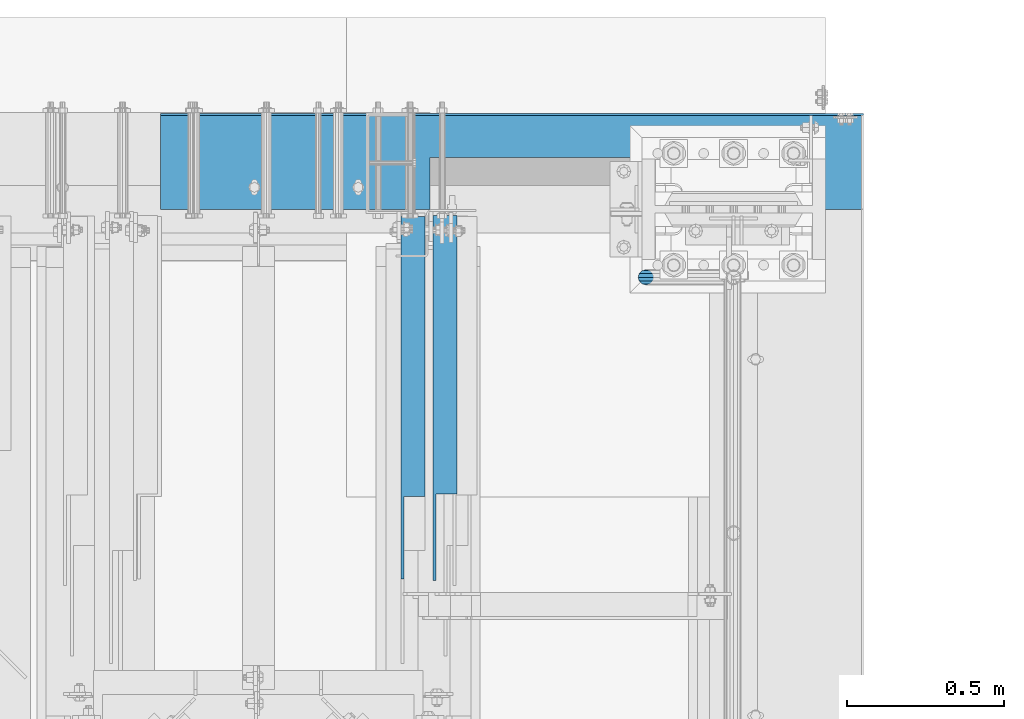
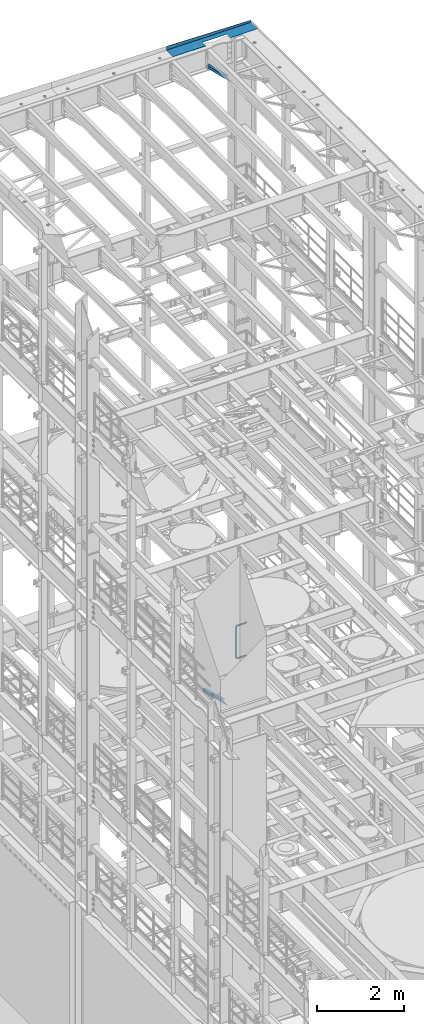
# One storey, part 1074 of 1876: 4 beams, 4 elements without a shape of their own.
"""IFC2X3 building model written with IfcOpenShell, lengths in millimetres."""

from ifc_helpers import new_model, si_unit, frame, origin_with_axes, place, context, subcontext, project, spatial, faceted_brep, material, type_object, element, aggregate, save


model = new_model("IFC2X3")

# Units and contexts
model_context = context("Model", 3, precision=1e-05, world=origin_with_axes())
body_context = subcontext(model_context, "Body", "Model", "MODEL_VIEW")
ifc_project = project(units=[si_unit("LENGTHUNIT", "METRE", prefix="MILLI"), si_unit("AREAUNIT", "SQUARE_METRE"), si_unit("VOLUMEUNIT", "CUBIC_METRE"), si_unit("MASSUNIT", "GRAM", prefix="KILO"), si_unit("TIMEUNIT", "SECOND"), si_unit("PLANEANGLEUNIT", "RADIAN"), si_unit("SOLIDANGLEUNIT", "STERADIAN"), si_unit("THERMODYNAMICTEMPERATUREUNIT", "DEGREE_CELSIUS"), si_unit("LUMINOUSINTENSITYUNIT", "LUMEN")], contexts=[model_context])

# Site, building, storey
site_placement = place(None, origin_with_axes())
site = spatial("IfcSite", under=ifc_project, at=site_placement, CompositionType="ELEMENT")
building_placement = place(site_placement, origin_with_axes())
building = spatial("IfcBuilding", under=site, at=building_placement, Name="Undefined", CompositionType="ELEMENT")
storey_placement = place(building_placement, origin_with_axes())
storey = spatial("IfcBuildingStorey", under=building, at=storey_placement, Name="Undefined", CompositionType="ELEMENT", Elevation=0.0)

# Assembly, beam
assembly_1_placement = place(storey_placement, origin_with_axes())
assembly_1 = element("IfcElementAssembly", 1, at=assembly_1_placement, inside=storey, Name="RAIL", AssemblyPlace="NOTDEFINED", PredefinedType="RIGID_FRAME")
ifc_material_1 = material()
beam_type_1 = type_object("IfcBeamType", Name="PIPE1-1/2SCH40", PredefinedType="NOTDEFINED")
beam_1_placement = place(assembly_1_placement, frame((7619.99999999999, 13499.7063, 6207.125), z_axis=(0.0, 0.0, 1.0), x_axis=(-1.0, 0.0, 0.0)))
beam_1 = element("IfcBeam", 2, at=beam_1_placement, type_object=beam_type_1, material=ifc_material_1, Name="RAIL", ObjectType="PIPE1-1/2SCH40", context=body_context, shape_type="Brep", body=[
    faceted_brep([(1.20714750983051e-12, 24.1299999999974, -914.399963378906), (12.0650000000014, 20.8971929933159, -926.464963378905), (12.0650000000014, 20.8971929933177, -902.334963378908), (12.0650000000014, -20.8971929933195, -902.334963378908), (12.0650000000014, -20.8971929933195, -926.464963378905), (1.52133659548828e-12, -24.130000000001, -914.399963378906), (20.8971929933199, -12.0650000000023, -893.502770385589), (20.8971929933199, -12.0650000000005, -898.533841947723), (15.2545715621378, -17.7076214311819, -904.176463378906), (12.5151929933181, -20.4470000000019, -914.399963378906), (15.2545715621376, -17.7076214311819, -924.623463378906), (20.8971929933199, -12.0650000000005, -930.26608481009), (20.8971929933199, -12.0650000000023, -935.297156372224), (24.1300000000014, -1.81898940354586e-12, -934.846963378906), (24.1300000000014, -1.81898940354586e-12, -938.529963378907), (21.3906214311813, -10.2235000000019, -932.107584810088), (21.3906214311823, 10.2234999999982, -932.107584810088), (20.8971929933199, 12.0650000000005, -930.266084810086), (20.8971929933199, 12.0649999999987, -935.297156372224), (15.2545715621413, 17.7076214311783, -924.623463378906), (12.5151929933216, 20.4469999999983, -914.399963378906), (15.2545715621411, 17.7076214311783, -904.176463378906), (20.8971929933199, 12.0650000000005, -898.533841947727), (20.8971929933199, 12.0649999999987, -893.502770385589), (21.3906214311822, 10.2234999999982, -896.692341947724), (24.1300000000014, 0.0, -893.952963378906), (24.1300000000014, 0.0, -890.269963378905), (21.3906214311814, -10.2235000000019, -896.692341947724), (241.299995422363, 20.8971929933177, -12.0649999999987), (241.299995422363, 24.1299999999992, 0.0), (253.073542436527, 24.1299999999992, -1.86474665447167), (249.345252399393, 20.8971929933177, -13.3392435235728), (241.299995422363, 12.0650000000005, -20.8971929933177), (246.615954666858, 12.0650000000005, -21.7391582230448), (241.299995422363, 0.0, -24.130000000001), (245.616962362259, 0.0, -24.8137403926739), (241.299995422363, -12.0650000000005, -20.8971929933177), (246.615954666858, -12.0650000000005, -21.7391582230448), (241.299995422363, -20.8971929933177, -12.0649999999987), (249.345252399393, -20.8971929933177, -13.3392435235728), (241.299995422363, -24.1299999999992, 0.0), (253.073542436527, -24.1299999999992, -1.86474665447167), (241.299995422363, -20.8971929933177, 12.0649999999987), (256.801832473661, -20.8971929933177, 9.60975021462946), (241.299995422363, -12.0650000000005, 20.8971929933177), (259.531130206197, -12.0650000000005, 18.0096649141014), (241.299995422363, 0.0, 24.130000000001), (260.530122510796, 0.0, 21.084247083727), (241.299995422363, 12.0650000000005, 20.8971929933177), (259.531130206197, 12.0650000000005, 18.0096649141014), (241.299995422363, 20.8971929933177, 12.0649999999987), (256.801832473661, 20.8971929933177, 9.60975021462946), (291.464993896486, -20.8971929933177, -38.0999984741211), (279.399993896484, -24.1299999999992, -38.0999984741211), (279.399993896484, -24.1299999999992, -876.299964904785), (291.464993896484, -20.8971929933177, -876.299964904785), (267.334993896485, -20.8971929933177, -38.0999984741211), (267.334993896484, -20.8971929933177, -876.299964904785), (258.502800903167, -12.0650000000005, -38.0999984741211), (258.502800903166, -12.0650000000005, -876.299964904785), (255.269993896485, 0.0, -38.0999984741211), (255.269993896484, 0.0, -876.299964904785), (258.502800903167, 12.0650000000005, -38.0999984741211), (258.502800903166, 12.0650000000005, -876.299964904785), (267.334993896485, 20.8971929933177, -38.0999984741211), (267.334993896484, 20.8971929933177, -876.299964904785), (279.399993896485, 24.1299999999992, -38.0999984741211), (279.399993896484, 24.1299999999992, -876.299964904785), (291.464993896486, 20.8971929933177, -38.0999984741211), (291.464993896484, 20.8971929933177, -876.299964904785), (300.297186889804, 12.0650000000005, -38.0999984741211), (300.297186889803, 12.0650000000005, -876.299964904785), (303.529993896486, 0.0, -38.0999984741211), (303.529993896484, 0.0, -876.299964904785), (300.297186889804, -12.0650000000005, -38.0999984741211), (300.297186889803, -12.0650000000005, -876.299964904785), (297.409658810584, -12.0650000000005, -894.531099688622), (300.484240980214, 0.0, -895.53009199322), (297.409658810584, 12.0650000000005, -894.531099688622), (289.009744111112, 20.8971929933177, -891.801801956084), (277.535247242011, 24.1299999999992, -888.073511918952), (266.06075037291, 20.8971929933177, -884.345221881817), (257.660835673438, 12.0650000000005, -881.615924149282), (254.586253503809, 0.0, -880.616931844681), (257.660835673438, -12.0650000000005, -881.615924149282), (266.06075037291, -20.8971929933177, -884.345221881817), (277.535247242011, -24.130000000001, -888.073511918952), (289.009744111112, -20.8971929933195, -891.801801956084), (241.299995422363, -20.8971929933195, -902.334963378908), (241.299995422363, -12.0650000000005, -893.502770385589), (241.299995422363, -24.130000000001, -914.399963378906), (241.299995422364, -20.8971929933195, -926.464963378909), (241.299995422364, -12.0650000000005, -935.297156372228), (241.299995422364, -1.81898940354586e-12, -938.529963378911), (241.299995422364, 12.0649999999987, -935.297156372228), (241.299995422364, 20.8971929933177, -926.464963378909), (241.299995422364, 24.1299999999992, -914.39996337891), (241.299995422363, 20.8971929933177, -902.334963378908), (241.299995422363, 12.0649999999987, -893.502770385589), (241.299995422363, 0.0, -890.269963378909), (245.61696236226, 0.0, -889.586222986232), (246.615954666859, -12.0650000000005, -892.660805155861), (246.615954666859, 12.0649999999987, -892.660805155861), (249.345252399395, 20.8971929933177, -901.060719855333), (253.07354243653, 24.1299999999992, -912.535216724435), (256.801832473666, 20.8971929933177, -924.009713593536), (259.531130206202, 12.0649999999987, -932.409628293008), (260.530122510801, 0.0, -935.484210462637), (259.531130206201, -12.0650000000005, -932.409628293008), (256.801832473666, -20.8971929933195, -924.009713593536), (253.07354243653, -24.130000000001, -912.535216724435), (249.345252399395, -20.8971929933195, -901.060719855333), (251.411550782037, -12.0650000000005, -890.21732688968), (256.602983568912, -20.8971929933195, -897.362721118872), (249.511354500001, 0.0, -887.601931081743), (251.411550782037, 12.0650000000005, -890.21732688968), (256.602983568912, 20.8971929933177, -897.362721118872), (263.694612637823, 24.1299999999992, -907.123511156005), (270.786241706733, 20.8971929933177, -916.884301193139), (275.977674493594, 12.0649999999987, -924.029695422345), (277.877870775644, 0.0, -926.645091230272), (275.977674493608, -12.0650000000005, -924.029695422334), (270.786241706733, -20.8971929933195, -916.884301193139), (263.694612637823, -24.130000000001, -907.123511156005), (262.362751636451, -20.8971929933195, -891.602953051333), (272.123541673585, -24.130000000001, -898.694582120243), (255.217357407258, -12.0650000000005, -886.411520264461), (252.601961599318, 0.0, -884.511323982424), (255.217357407258, 12.0650000000005, -886.411520264461), (262.362751636451, 20.8971929933177, -891.602953051333), (272.123541673585, 24.1299999999992, -898.694582120243), (281.884331710718, 20.8971929933177, -905.786211189152), (289.029725939912, 12.0650000000005, -910.977643976028), (291.645121747852, 0.0, -912.877840258065), (289.029725939912, -12.0650000000005, -910.977643976028), (281.884331710718, -20.8971929933195, -905.786211189152), (289.009744111112, -20.8971929933177, -22.5981614228222), (297.409658810584, -12.0650000000005, -19.8688636902843), (277.535247242011, -24.1299999999992, -26.3264514599541), (266.060750372911, -20.8971929933177, -30.0547414970897), (257.660835673439, -12.0650000000005, -32.7840392296275), (254.58625350381, 0.0, -33.7830315342253), (257.660835673439, 12.0650000000005, -32.7840392296275), (266.060750372911, 20.8971929933177, -30.0547414970897), (277.535247242011, 24.1299999999992, -26.3264514599541), (289.009744111112, 20.8971929933177, -22.5981614228222), (297.409658810584, 12.0650000000005, -19.8688636902843), (300.484240980213, 0.0, -18.8698713856866), (289.029725939909, -12.0650000000005, -3.42231940287456), (291.645121747848, 0.0, -1.52212312084157), (281.884331710716, -20.8971929933177, -8.61375218975081), (272.123541673583, -24.1299999999992, -15.7053812586601), (262.362751636451, -20.8971929933177, -22.7970103275729), (255.217357407257, -12.0650000000005, -27.9884431144455), (252.601961599318, 0.0, -29.8886393964822), (255.217357407257, 12.0650000000005, -27.9884431144455), (262.362751636451, 20.8971929933177, -22.7970103275729), (272.123541673583, 24.1299999999992, -15.7053812586601), (281.884331710716, 20.8971929933177, -8.61375218975081), (289.029725939909, 12.0650000000005, -3.42231940287456), (277.877870775642, 0.0, 12.2451278513654), (275.977674493607, 12.0650000000005, 9.62973204342416), (275.977674493607, -12.0650000000005, 9.62973204342416), (270.786241706732, -20.8971929933177, 2.48433781423228), (263.694612637822, -24.1299999999992, -7.27645222290084), (256.602983568912, -20.8971929933177, -17.037242260034), (251.411550782037, -12.0650000000005, -24.1826364892258), (249.511354500002, 0.0, -26.7980322971671), (251.411550782037, 12.0650000000005, -24.1826364892258), (256.602983568912, 20.8971929933177, -17.037242260034), (263.694612637822, 24.1299999999992, -7.27645222290084), (270.786241706732, 20.8971929933177, 2.48433781423228), (24.1300000000047, 24.1299999999992, 0.0), (20.8971929933232, 20.8971929933177, 12.0649999999987), (12.0650000000041, 12.0650000000005, 20.8971929933177), (-1.45519152283669e-11, 0.0, 24.130000000001), (-12.0649999999951, -12.0650000000005, 20.8971929933177), (-20.8971929933141, -20.8971929933177, 12.0649999999987), (0.0, -24.1299999999992, 0.0), (-24.1299999999956, -24.1299999999992, 0.0), (-12.0650000000096, -20.8971929933177, -12.0649999999987), (12.0650000000064, -20.8971929933177, -12.0649999999987), (-20.8971929933141, -20.8971929933177, -12.0649999999987), (-12.0649999999951, -12.0650000000005, -20.8971929933177), (20.8971929933249, -12.0650000000005, -20.8971929933177), (-16.481093238739, -16.4810932387427, -16.4810997545756), (24.1300000000063, 0.0, -24.130000000001), (-1.45519152283669e-11, 0.0, -24.130000000001), (20.8971929933249, 12.0650000000005, -20.8971929933177), (12.0650000000041, 12.0650000000005, -20.8971929933177), (20.8971929933232, 20.8971929933177, -12.0649999999987), (16.481099754581, 16.4810997545774, -16.4810932387409), (241.299995422363, -17.7076214311801, 10.2235000000001), (241.299995422363, -20.4470000000001, 0.0), (-20.4469999999956, -20.4470000000001, 0.0), (-17.7076214311755, -17.7076214311801, 10.2235000000001), (241.299995422363, -17.7076214311801, -10.2235000000001), (-17.7076214311755, -17.7076214311801, -10.2235000000001), (241.299995422363, -10.2235000000001, -17.7076214311819), (-10.2234999999955, -10.2235000000001, -17.7076214311819), (241.299995422363, 0.0, -20.4470000000001), (-1.45519152283669e-11, 0.0, -20.4470000000001), (241.299995422363, 10.2235000000001, -17.7076214311819), (10.2235000000046, 10.2235000000001, -17.7076214311819), (241.299995422363, 17.7076214311801, -10.2235000000001), (17.7076214311846, 17.7076214311801, -10.2235000000001), (241.299995422363, 20.4470000000001, 0.0), (20.4470000000047, 20.4470000000001, 0.0), (241.299995422363, 0.0, 20.4470000000001), (241.299995422363, -10.2235000000001, 17.7076214311819), (-10.2234999999955, -10.2235000000001, 17.7076214311819), (-1.45519152283669e-11, 0.0, 20.4470000000001), (241.299995422363, 10.2235000000001, 17.7076214311819), (10.2235000000046, 10.2235000000001, 17.7076214311819), (241.299995422363, 17.7076214311801, 10.2235000000001), (17.7076214311846, 17.7076214311801, 10.2235000000001), (258.545498388721, -10.2235000000001, 14.9762020957387), (256.23277767852, -17.7076214311801, 7.85837963987069), (253.073542436527, -20.4470000000001, -1.86474665447167), (249.914307194535, -17.7076214311801, -11.5878729488177), (247.601586484334, -10.2235000000001, -18.7056954046857), (246.755071952542, 0.0, -21.31099924316), (247.601586484334, 10.2235000000001, -18.7056954046857), (249.914307194535, 17.7076214311801, -11.5878729488177), (253.073542436527, 20.4470000000001, -1.86474665447167), (256.23277767852, 17.7076214311801, 7.85837963987069), (258.545498388721, 10.2235000000001, 14.9762020957387), (259.392012920513, 0.0, 17.5815059342131), (275.713057691449, 0.0, 9.26551826108334), (274.10289136825, -10.2235000000001, 7.04931444488102), (274.10289136825, 10.2235000000001, 7.04931444488102), (269.703835164635, 17.7076214311801, 0.994533019089431), (263.694612637822, 20.4470000000001, -7.27645222290084), (257.685390111009, 17.7076214311801, -15.5474374648911), (253.286333907394, 10.2235000000001, -21.6022188906827), (251.676167584195, 0.0, -23.818422706885), (253.286333907394, -10.2235000000001, -21.6022188906827), (257.685390111009, -17.7076214311801, -15.5474374648911), (263.694612637822, -20.4470000000001, -7.27645222290084), (269.703835164635, -17.7076214311801, 0.994533019089431), (286.449308341364, -10.2235000000001, -5.29710252823133), (280.394526915574, -17.7076214311801, -9.69615873184739), (288.665512157566, 0.0, -3.68693620503473), (286.449308341364, 10.2235000000001, -5.29710252823133), (280.394526915574, 17.7076214311801, -9.69615873184739), (272.123541673583, 20.4470000000001, -15.7053812586601), (263.852556431592, 17.7076214311801, -21.7146037854764), (257.797775005802, 10.2235000000001, -26.1136599890888), (255.581571189601, 0.0, -27.723826312289), (257.797775005802, -10.2235000000001, -26.1136599890888), (263.852556431592, -17.7076214311801, -21.7146037854764), (272.123541673583, -20.4470000000001, -15.7053812586601), (287.258373536355, -17.7076214311801, -23.1672162179639), (277.535247242011, -20.4470000000001, -26.3264514599541), (294.376195992223, -10.2235000000001, -20.8544955077632), (296.981499830698, 0.0, -20.00798097597), (294.376195992223, 10.2235000000001, -20.8544955077632), (287.258373536355, 17.7076214311801, -23.1672162179639), (277.535247242011, 20.4470000000001, -26.3264514599541), (267.812120947668, 17.7076214311801, -29.485686701948), (260.6942984918, 10.2235000000001, -31.7984074121487), (258.088994653325, 0.0, -32.6449219439419), (260.6942984918, -10.2235000000001, -31.7984074121487), (267.812120947668, -17.7076214311801, -29.485686701948), (279.399993896484, -20.4470000000001, -38.0999984741211), (269.176493896485, -17.7076214311801, -38.0999984741211), (289.623493896486, -17.7076214311801, -38.0999984741211), (297.107615327666, -10.2235000000001, -38.0999984741211), (299.846993896486, 0.0, -38.0999984741211), (297.107615327666, 10.2235000000001, -38.0999984741211), (289.623493896486, 17.7076214311801, -38.0999984741211), (279.399993896485, 20.4470000000001, -38.0999984741211), (269.176493896485, 17.7076214311801, -38.0999984741211), (261.692372465305, 10.2235000000001, -38.0999984741211), (258.952993896485, 0.0, -38.0999984741211), (261.692372465305, -10.2235000000001, -38.0999984741211), (269.176493896484, -17.7076214311801, -876.299964904785), (261.692372465304, -10.2235000000001, -876.299964904785), (258.952993896484, 0.0, -876.299964904785), (261.692372465304, 10.2235000000001, -876.299964904785), (269.176493896484, 17.7076214311801, -876.299964904785), (279.399993896484, 20.4470000000001, -876.299964904785), (289.623493896484, 17.7076214311801, -876.299964904785), (297.107615327665, 10.2235000000001, -876.299964904785), (299.846993896484, 0.0, -876.299964904785), (297.107615327665, -10.2235000000001, -876.299964904785), (289.623493896484, -17.7076214311801, -876.299964904785), (279.399993896484, -20.4470000000001, -876.299964904785), (277.535247242011, -20.4470000000001, -888.073511918952), (267.812120947667, -17.7076214311801, -884.914276676958), (260.694298491799, -10.2235000000001, -882.601555966758), (258.088994653324, 0.0, -881.755041434964), (260.694298491799, 10.2235000000001, -882.601555966758), (267.812120947668, 17.7076214311801, -884.914276676958), (277.535247242011, 20.4470000000001, -888.073511918952), (287.258373536355, 17.7076214311801, -891.232747160942), (294.376195992223, 10.2235000000001, -893.545467871143), (296.981499830699, 0.0, -894.391982402936), (294.376195992223, -10.2235000000001, -893.545467871143), (287.258373536355, -17.7076214311801, -891.232747160942), (280.394526915577, -17.7076214311801, -904.703804647055), (272.123541673585, -20.4470000000001, -898.694582120243), (286.449308341367, -10.2235000000001, -909.102860850671), (288.665512157569, 0.0, -910.713027173868), (286.449308341367, 10.2235000000001, -909.102860850671), (280.394526915577, 17.7076214311801, -904.703804647055), (272.123541673585, 20.4470000000001, -898.694582120243), (263.852556431593, 17.7076214311801, -892.68535959343), (257.797775005802, 10.2235000000001, -888.286303389817), (255.581571189601, 0.0, -886.676137066617), (257.797775005802, -10.2235000000001, -888.286303389817), (263.852556431593, -17.7076214311801, -892.68535959343), (263.694612637823, -20.4470000000001, -907.123511156005), (257.685390111009, -17.7076214311801, -898.852525914015), (269.703835164636, -17.7076214311801, -915.394496397999), (274.102891368238, -10.2235000000001, -921.449277823798), (275.71305769145, 0.0, -923.66548163999), (274.102891368251, 10.2235000000001, -921.449277823787), (269.703835164636, 17.7076214311801, -915.394496397999), (263.694612637823, 20.4470000000001, -907.123511156005), (257.685390111009, 17.7076214311801, -898.852525914015), (253.286333907394, 10.2235000000001, -892.797744488227), (251.676167584195, 0.0, -890.581540672025), (253.286333907394, -10.2235000000001, -892.797744488227), (249.914307194537, -17.7076214311801, -902.812090430092), (247.601586484335, -10.2235000000001, -895.694267974224), (253.07354243653, -20.4470000000001, -912.535216724435), (256.232777678524, -17.7076214311819, -922.258343018777), (258.545498388725, -10.2235000000001, -929.376165474645), (259.392012920517, 0.0, -931.981469313119), (258.545498388725, 10.2235000000001, -929.376165474645), (256.232777678524, 17.7076214311801, -922.258343018777), (253.07354243653, 20.4470000000001, -912.535216724435), (249.914307194537, 17.7076214311801, -902.812090430092), (247.601586484335, 10.2235000000001, -895.694267974224), (246.755071952543, 0.0, -893.088964135746), (241.299995422363, -10.2235000000001, -896.692341947728), (241.299995422363, 0.0, -893.95296337891), (241.299995422363, -17.7076214311819, -904.17646337891), (241.299995422363, -20.4470000000001, -914.399963378906), (241.299995422364, -17.7076214311819, -924.62346337891), (241.299995422364, -10.2235000000001, -932.107584810088), (241.299995422364, -1.81898940354586e-12, -934.84696337891), (241.299995422364, 10.2234999999982, -932.107584810088), (241.299995422364, 17.7076214311801, -924.62346337891), (241.299995422364, 20.4470000000001, -914.39996337891), (241.299995422363, 17.7076214311801, -904.17646337891), (241.299995422363, 10.2235000000001, -896.692341947728)], [[[0, 1, 2]], [[3, 4, 5]], [[6, 7, 8, 9, 10, 11, 12, 4, 3]], [[13, 14, 12, 11, 15]], [[16, 17, 18, 14, 13]], [[2, 1, 18, 17, 19, 20, 21, 22, 23]], [[23, 22, 24, 25, 26]], [[26, 25, 27, 7, 6]], [[28, 29, 30, 31]], [[32, 28, 31, 33]], [[34, 32, 33, 35]], [[36, 34, 35, 37]], [[38, 36, 37, 39]], [[40, 38, 39, 41]], [[42, 40, 41, 43]], [[44, 42, 43, 45]], [[46, 44, 45, 47]], [[48, 46, 47, 49]], [[50, 48, 49, 51]], [[52, 53, 54, 55]], [[53, 56, 57, 54]], [[56, 58, 59, 57]], [[58, 60, 61, 59]], [[60, 62, 63, 61]], [[62, 64, 65, 63]], [[64, 66, 67, 65]], [[66, 68, 69, 67]], [[68, 70, 71, 69]], [[70, 72, 73, 71]], [[72, 74, 75, 73]], [[73, 75, 76, 77]], [[71, 73, 77, 78]], [[69, 71, 78, 79]], [[67, 69, 79, 80]], [[65, 67, 80, 81]], [[63, 65, 81, 82]], [[61, 63, 82, 83]], [[59, 61, 83, 84]], [[57, 59, 84, 85]], [[54, 57, 85, 86]], [[55, 54, 86, 87]], [[88, 89, 6, 3]], [[90, 88, 3, 5]], [[91, 90, 5, 4]], [[92, 91, 4, 12]], [[93, 92, 12, 14]], [[94, 93, 14, 18]], [[95, 94, 18, 1]], [[96, 95, 1, 0]], [[97, 96, 0, 2]], [[98, 97, 2, 23]], [[99, 98, 23, 26]], [[89, 99, 26, 6]], [[100, 99, 89, 101]], [[102, 98, 99, 100]], [[103, 97, 98, 102]], [[104, 96, 97, 103]], [[105, 95, 96, 104]], [[106, 94, 95, 105]], [[107, 93, 94, 106]], [[108, 92, 93, 107]], [[109, 91, 92, 108]], [[110, 90, 91, 109]], [[111, 88, 90, 110]], [[101, 89, 88, 111]], [[112, 101, 111, 113]], [[114, 100, 101, 112]], [[115, 102, 100, 114]], [[116, 103, 102, 115]], [[117, 104, 103, 116]], [[118, 105, 104, 117]], [[119, 106, 105, 118]], [[120, 107, 106, 119]], [[121, 108, 107, 120]], [[122, 109, 108, 121]], [[123, 110, 109, 122]], [[113, 111, 110, 123]], [[124, 113, 123, 125]], [[126, 112, 113, 124]], [[127, 114, 112, 126]], [[128, 115, 114, 127]], [[129, 116, 115, 128]], [[130, 117, 116, 129]], [[131, 118, 117, 130]], [[132, 119, 118, 131]], [[133, 120, 119, 132]], [[134, 121, 120, 133]], [[135, 122, 121, 134]], [[125, 123, 122, 135]], [[86, 125, 135, 87]], [[85, 124, 125, 86]], [[84, 126, 124, 85]], [[83, 127, 126, 84]], [[82, 128, 127, 83]], [[81, 129, 128, 82]], [[80, 130, 129, 81]], [[79, 131, 130, 80]], [[78, 132, 131, 79]], [[77, 133, 132, 78]], [[76, 134, 133, 77]], [[87, 135, 134, 76]], [[75, 55, 87, 76]], [[74, 52, 55, 75]], [[136, 52, 74, 137]], [[138, 53, 52, 136]], [[139, 56, 53, 138]], [[140, 58, 56, 139]], [[141, 60, 58, 140]], [[142, 62, 60, 141]], [[143, 64, 62, 142]], [[144, 66, 64, 143]], [[145, 68, 66, 144]], [[146, 70, 68, 145]], [[147, 72, 70, 146]], [[137, 74, 72, 147]], [[148, 137, 147, 149]], [[150, 136, 137, 148]], [[151, 138, 136, 150]], [[152, 139, 138, 151]], [[153, 140, 139, 152]], [[154, 141, 140, 153]], [[155, 142, 141, 154]], [[156, 143, 142, 155]], [[157, 144, 143, 156]], [[158, 145, 144, 157]], [[159, 146, 145, 158]], [[149, 147, 146, 159]], [[160, 149, 159, 161]], [[162, 148, 149, 160]], [[163, 150, 148, 162]], [[164, 151, 150, 163]], [[165, 152, 151, 164]], [[166, 153, 152, 165]], [[167, 154, 153, 166]], [[168, 155, 154, 167]], [[169, 156, 155, 168]], [[170, 157, 156, 169]], [[171, 158, 157, 170]], [[161, 159, 158, 171]], [[49, 161, 171, 51]], [[47, 160, 161, 49]], [[45, 162, 160, 47]], [[43, 163, 162, 45]], [[41, 164, 163, 43]], [[39, 165, 164, 41]], [[37, 166, 165, 39]], [[35, 167, 166, 37]], [[33, 168, 167, 35]], [[31, 169, 168, 33]], [[30, 170, 169, 31]], [[51, 171, 170, 30]], [[29, 50, 51, 30]], [[50, 29, 172, 173]], [[48, 50, 173, 174]], [[46, 48, 174, 175]], [[44, 46, 175, 176]], [[42, 44, 176, 177]], [[178, 40, 42, 177, 179]], [[180, 181, 38, 40, 178, 179, 182]], [[183, 184, 36, 38, 181, 180, 182, 185]], [[186, 34, 36, 184, 183, 187]], [[188, 32, 34, 186, 187, 189]], [[190, 28, 32, 188, 189, 191]], [[29, 28, 190, 172]], [[192, 193, 194, 195]], [[193, 196, 197, 194]], [[196, 198, 199, 197]], [[198, 200, 201, 199]], [[200, 202, 203, 201]], [[202, 204, 205, 203]], [[204, 206, 207, 205]], [[208, 209, 210, 211]], [[212, 208, 211, 213]], [[214, 212, 213, 215]], [[206, 214, 215, 207]], [[191, 189, 187, 183, 185, 182, 179, 177, 176, 175, 174, 173, 172, 190], [213, 211, 210, 195, 194, 197, 199, 201, 203, 205, 207, 215]], [[209, 192, 195, 210]], [[192, 209, 216, 217]], [[193, 192, 217, 218]], [[196, 193, 218, 219]], [[198, 196, 219, 220]], [[200, 198, 220, 221]], [[202, 200, 221, 222]], [[204, 202, 222, 223]], [[206, 204, 223, 224]], [[214, 206, 224, 225]], [[212, 214, 225, 226]], [[208, 212, 226, 227]], [[209, 208, 227, 216]], [[227, 228, 229, 216]], [[226, 230, 228, 227]], [[225, 231, 230, 226]], [[224, 232, 231, 225]], [[223, 233, 232, 224]], [[222, 234, 233, 223]], [[221, 235, 234, 222]], [[220, 236, 235, 221]], [[219, 237, 236, 220]], [[218, 238, 237, 219]], [[217, 239, 238, 218]], [[216, 229, 239, 217]], [[229, 240, 241, 239]], [[228, 242, 240, 229]], [[230, 243, 242, 228]], [[231, 244, 243, 230]], [[232, 245, 244, 231]], [[233, 246, 245, 232]], [[234, 247, 246, 233]], [[235, 248, 247, 234]], [[236, 249, 248, 235]], [[237, 250, 249, 236]], [[238, 251, 250, 237]], [[239, 241, 251, 238]], [[241, 252, 253, 251]], [[240, 254, 252, 241]], [[242, 255, 254, 240]], [[243, 256, 255, 242]], [[244, 257, 256, 243]], [[245, 258, 257, 244]], [[246, 259, 258, 245]], [[247, 260, 259, 246]], [[248, 261, 260, 247]], [[249, 262, 261, 248]], [[250, 263, 262, 249]], [[251, 253, 263, 250]], [[253, 264, 265, 263]], [[252, 266, 264, 253]], [[254, 267, 266, 252]], [[255, 268, 267, 254]], [[256, 269, 268, 255]], [[257, 270, 269, 256]], [[258, 271, 270, 257]], [[259, 272, 271, 258]], [[260, 273, 272, 259]], [[261, 274, 273, 260]], [[262, 275, 274, 261]], [[263, 265, 275, 262]], [[275, 265, 276, 277]], [[274, 275, 277, 278]], [[273, 274, 278, 279]], [[272, 273, 279, 280]], [[271, 272, 280, 281]], [[270, 271, 281, 282]], [[269, 270, 282, 283]], [[268, 269, 283, 284]], [[267, 268, 284, 285]], [[266, 267, 285, 286]], [[264, 266, 286, 287]], [[265, 264, 287, 276]], [[276, 287, 288, 289]], [[277, 276, 289, 290]], [[278, 277, 290, 291]], [[279, 278, 291, 292]], [[280, 279, 292, 293]], [[281, 280, 293, 294]], [[282, 281, 294, 295]], [[283, 282, 295, 296]], [[284, 283, 296, 297]], [[285, 284, 297, 298]], [[286, 285, 298, 299]], [[287, 286, 299, 288]], [[299, 300, 301, 288]], [[298, 302, 300, 299]], [[297, 303, 302, 298]], [[296, 304, 303, 297]], [[295, 305, 304, 296]], [[294, 306, 305, 295]], [[293, 307, 306, 294]], [[292, 308, 307, 293]], [[291, 309, 308, 292]], [[290, 310, 309, 291]], [[289, 311, 310, 290]], [[288, 301, 311, 289]], [[301, 312, 313, 311]], [[300, 314, 312, 301]], [[302, 315, 314, 300]], [[303, 316, 315, 302]], [[304, 317, 316, 303]], [[305, 318, 317, 304]], [[306, 319, 318, 305]], [[307, 320, 319, 306]], [[308, 321, 320, 307]], [[309, 322, 321, 308]], [[310, 323, 322, 309]], [[311, 313, 323, 310]], [[313, 324, 325, 323]], [[312, 326, 324, 313]], [[314, 327, 326, 312]], [[315, 328, 327, 314]], [[316, 329, 328, 315]], [[317, 330, 329, 316]], [[318, 331, 330, 317]], [[319, 332, 331, 318]], [[320, 333, 332, 319]], [[321, 334, 333, 320]], [[322, 335, 334, 321]], [[323, 325, 335, 322]], [[325, 336, 337, 335]], [[324, 338, 336, 325]], [[326, 339, 338, 324]], [[327, 340, 339, 326]], [[328, 341, 340, 327]], [[329, 342, 341, 328]], [[330, 343, 342, 329]], [[331, 344, 343, 330]], [[332, 345, 344, 331]], [[333, 346, 345, 332]], [[334, 347, 346, 333]], [[335, 337, 347, 334]], [[347, 337, 25, 24]], [[21, 346, 347, 24, 22]], [[345, 346, 21, 20]], [[344, 345, 20, 19]], [[343, 344, 19, 17, 16]], [[342, 343, 16, 13]], [[341, 342, 13, 15]], [[10, 340, 341, 15, 11]], [[339, 340, 10, 9]], [[338, 339, 9, 8]], [[336, 338, 8, 7, 27]], [[337, 336, 27, 25]]]),
])
aggregate(assembly_1, [beam_1])

assembly_2_placement = place(storey_placement, origin_with_axes())
assembly_2 = element("IfcElementAssembly", 3, at=assembly_2_placement, inside=storey, AssemblyPlace="NOTDEFINED", PredefinedType="RIGID_FRAME")
ifc_material_2 = material(Name="STEEL/A36")
beam_type_2 = type_object("IfcBeamType", Name="L3X3X3/8", PredefinedType="NOTDEFINED")
beam_2_placement = place(assembly_2_placement, frame((6600.82500009537, 12830.5843372416, 4789.15168871849), z_axis=(1.0, 0.0, 0.0), x_axis=(0.0, 0.967147277703794, -0.254216724922142)))
beam_2 = element("IfcBeam", 4, at=beam_2_placement, type_object=beam_type_2, material=ifc_material_2, ObjectType="L3X3X3/8", context=body_context, shape_type="Brep", body=[
    faceted_brep([(0.0, 38.1000000000004, -38.1), (0.0, 38.1000000000004, 38.1), (881.684520949349, 38.1000000001804, 38.1000000000004), (881.684520949349, 38.1000000001804, -38.1000000000004), (-36.2371036914428, 28.5749999999935, 38.1000000000004), (881.696433462228, 28.5750000001808, 38.1000000000004), (-36.2371036914428, 28.5749999999935, -28.5749999999998), (881.696433462228, 28.5750000001808, -28.5749999999998), (-289.896829504256, -38.1000000000595, -28.5749999999998), (881.779821052378, -38.0999999998203, -28.5749999999998), (-289.896829504256, -38.1000000000595, -38.1000000000004), (881.779821052378, -38.0999999998203, -38.1000000000004)], [[[0, 1, 2, 3]], [[1, 4, 5, 2]], [[4, 6, 7, 5]], [[6, 8, 9, 7]], [[8, 10, 11, 9]], [[10, 0, 3, 11]], [[5, 7, 9, 11, 3, 2]], [[10, 8, 6, 4, 1, 0]]]),
])
aggregate(assembly_2, [beam_2])

assembly_3_placement = place(storey_placement, origin_with_axes())
assembly_3 = element("IfcElementAssembly", 5, at=assembly_3_placement, inside=storey, AssemblyPlace="NOTDEFINED", PredefinedType="RIGID_FRAME")
beam_3_placement = place(assembly_3_placement, frame((6702.425, 12840.8509533049, 22213.431722183), z_axis=(1.0, 0.0, 0.0), x_axis=(0.0, 0.970296005691371, -0.241920774923053)))
beam_3 = element("IfcBeam", 6, at=beam_3_placement, type_object=beam_type_2, material=ifc_material_2, ObjectType="L3X3X3/8", context=body_context, shape_type="Brep", body=[
    faceted_brep([(0.0, 38.1000000000004, -38.1), (0.0, 38.1000000000004, 38.1), (871.989692018896, 38.1000000003733, 38.1000000000004), (871.989692018896, 38.1000000003733, -38.1000000000004), (-38.2028763666676, 28.5750000000298, 38.1000000000004), (871.9896920189, 28.5750000003572, 38.1000000000004), (-38.2028763666676, 28.5750000000298, -28.5749999999998), (871.9896920189, 28.5750000003572, -28.5749999999998), (-305.623010913256, -38.1000000001623, -28.5749999999998), (871.989692018928, -38.0999999997366, -28.5749999999998), (-305.623010913256, -38.1000000001623, -38.1000000000004), (871.989692018928, -38.0999999997366, -38.1000000000004)], [[[0, 1, 2, 3]], [[1, 4, 5, 2]], [[4, 6, 7, 5]], [[6, 8, 9, 7]], [[8, 10, 11, 9]], [[10, 0, 3, 11]], [[5, 7, 9, 11, 3, 2]], [[10, 8, 6, 4, 1, 0]]]),
])
aggregate(assembly_3, [beam_3])

assembly_4_placement = place(storey_placement, origin_with_axes())
assembly_4 = element("IfcElementAssembly", 7, at=assembly_4_placement, inside=storey, Name="BENT PLATE", AssemblyPlace="NOTDEFINED", PredefinedType="RIGID_FRAME")
beam_type_3 = type_object("IfcBeamType", PredefinedType="NOTDEFINED")
beam_4_placement = place(assembly_4_placement, frame((6915.15, 13715.9999771422, 22558.3750000001), z_axis=(1.0, 0.0, 0.0), x_axis=(0.0, 0.999999999968684, -7.91400000071008e-06)))
beam_4 = element("IfcBeam", 8, at=beam_4_placement, type_object=beam_type_3, material=ifc_material_2, Name="BENT PLATE", context=body_context, shape_type="Brep", body=[
    faceted_brep([(165.100051822585, -3.17500005136753, -260.350008762141), (165.100006108934, 3.17499994863465, -260.350008762141), (9.877112461254e-10, 3.17499999999927, -260.350008762141), (-9.89530235528946e-10, -3.17499999999927, -260.350008762141), (165.100051822585, -3.17500005136753, 412.750027858952), (165.100006108934, 3.17499994863465, 412.750027858952), (-9.89530235528946e-10, -3.17499999999927, 412.750027858952), (9.877112461254e-10, 3.17499999999927, 412.750027858952), (298.449951181141, 3.1749999071435, -1117.6), (298.449951181141, 3.1749999071435, 1117.6), (298.449638092343, 63.3681527932458, 1117.6), (298.449394943349, 110.11496897375, -1117.6), (-9.88620740827173e-10, 3.17499999999927, 1117.6), (9.877112461254e-10, -3.17499999999927, 1117.6), (304.799984210134, -3.1750000948341, 1117.6), (304.799638092194, 63.3681985068943, 1117.6), (304.799984210134, -3.1750000948341, -1117.6), (304.799394943268, 110.115002002654, -1117.6), (9.877112461254e-10, -3.17499999999927, -1117.6), (-9.88620740827173e-10, 3.17499999999927, -1117.6)], [[[0, 1, 2, 3]], [[4, 5, 1, 0]], [[6, 7, 5, 4]], [[8, 9, 10, 11]], [[9, 12, 13, 14, 15, 10]], [[14, 16, 17, 15]], [[11, 10, 15, 17]], [[16, 18, 19, 8, 11, 17]], [[19, 18, 3, 2]], [[12, 9, 8, 19, 2, 1, 5, 7]], [[13, 12, 7, 6]], [[3, 18, 16, 14, 13, 6, 4, 0]]]),
])
aggregate(assembly_4, [beam_4])

save(model, "model.ifc")
